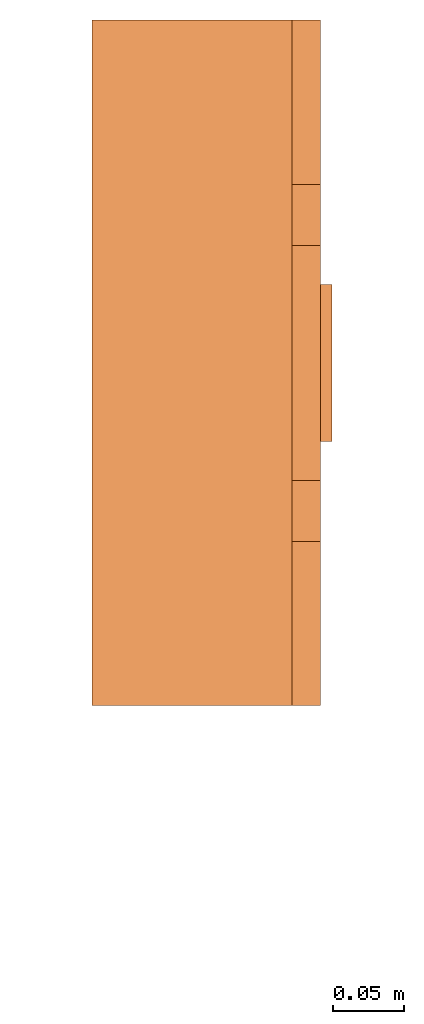
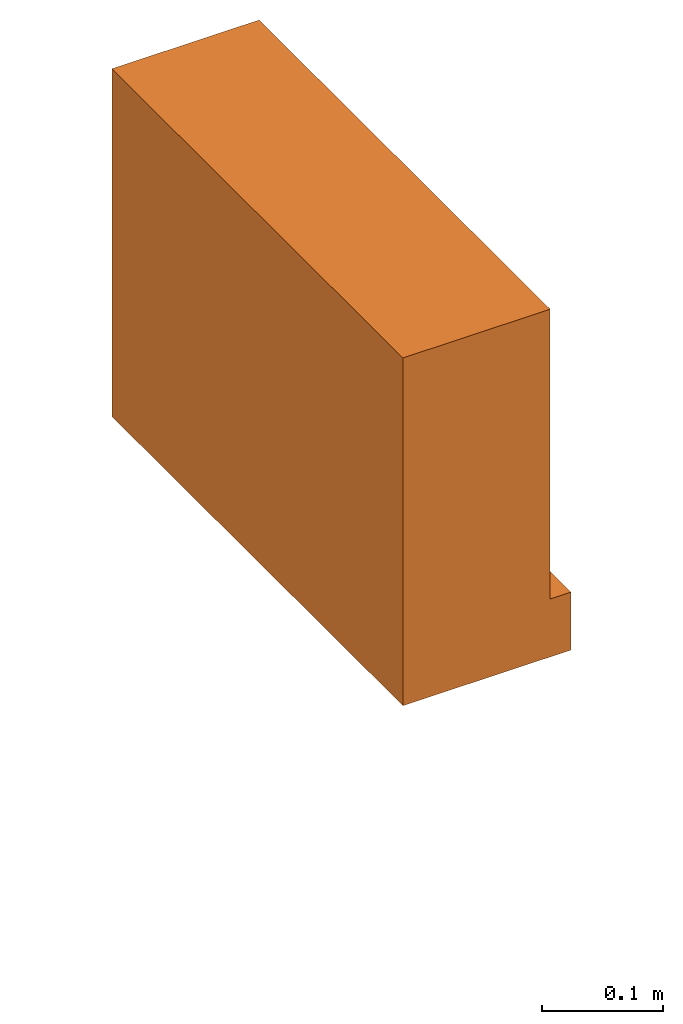
# One storey, part 3 of 3: 1 proxy.
"""IFC2X3 building model written with IfcOpenShell, lengths in millimetres."""

from ifc_helpers import new_model, entity, si_unit, converted_unit, derived_unit, direction, frame, origin, place, context, subcontext, project, spatial, faceted_brep, source, transform, mapped, material, material_list, type_object, type_shapes, element, save


model = new_model("IFC2X3")

# Units and contexts
model_context = context("Model", 3, precision=0.01, world=origin(), true_north=direction((6.12303176911189e-17, 1.0)))
body_context = subcontext(model_context, "Body", "Model", "MODEL_VIEW")
ifc_project = project(units=[si_unit("LENGTHUNIT", "METRE", prefix="MILLI"), si_unit("AREAUNIT", "SQUARE_METRE"), si_unit("VOLUMEUNIT", "CUBIC_METRE"), converted_unit("PLANEANGLEUNIT", "DEGREE", entity("IfcRatioMeasure", 0.0174532925199433), si_unit("PLANEANGLEUNIT", "RADIAN"), dimensions=[0, 0, 0, 0, 0, 0, 0]), si_unit("MASSUNIT", "GRAM", prefix="KILO"), derived_unit("MASSDENSITYUNIT", [(si_unit("MASSUNIT", "GRAM", prefix="KILO"), 1), (si_unit("LENGTHUNIT", "METRE"), -3)]), derived_unit("MOMENTOFINERTIAUNIT", [(si_unit("LENGTHUNIT", "METRE"), 4)]), si_unit("TIMEUNIT", "SECOND"), si_unit("FREQUENCYUNIT", "HERTZ"), si_unit("THERMODYNAMICTEMPERATUREUNIT", "DEGREE_CELSIUS"), derived_unit("THERMALTRANSMITTANCEUNIT", [(si_unit("MASSUNIT", "GRAM", prefix="KILO"), 1), (si_unit("THERMODYNAMICTEMPERATUREUNIT", "KELVIN"), -1), (si_unit("TIMEUNIT", "SECOND"), -3)]), derived_unit("VOLUMETRICFLOWRATEUNIT", [(si_unit("LENGTHUNIT", "METRE"), 3), (si_unit("TIMEUNIT", "SECOND"), -1)]), derived_unit("MASSFLOWRATEUNIT", [(si_unit("MASSUNIT", "GRAM", prefix="KILO"), 1), (si_unit("TIMEUNIT", "SECOND"), -1)]), derived_unit("ROTATIONALFREQUENCYUNIT", [(si_unit("TIMEUNIT", "SECOND"), -1)]), si_unit("ELECTRICCURRENTUNIT", "AMPERE"), si_unit("ELECTRICVOLTAGEUNIT", "VOLT"), si_unit("POWERUNIT", "WATT"), si_unit("FORCEUNIT", "NEWTON", prefix="KILO"), si_unit("ILLUMINANCEUNIT", "LUX"), si_unit("LUMINOUSFLUXUNIT", "LUMEN"), si_unit("LUMINOUSINTENSITYUNIT", "CANDELA"), derived_unit("USERDEFINED", [(si_unit("MASSUNIT", "GRAM", prefix="KILO"), -1), (si_unit("LENGTHUNIT", "METRE"), -2), (si_unit("TIMEUNIT", "SECOND"), 3), (si_unit("LUMINOUSFLUXUNIT", "LUMEN"), 1)]), derived_unit("LINEARVELOCITYUNIT", [(si_unit("LENGTHUNIT", "METRE"), 1), (si_unit("TIMEUNIT", "SECOND"), -1)]), si_unit("PRESSUREUNIT", "PASCAL"), derived_unit("USERDEFINED", [(si_unit("LENGTHUNIT", "METRE"), -2), (si_unit("MASSUNIT", "GRAM", prefix="KILO"), 1), (si_unit("TIMEUNIT", "SECOND"), -2)]), derived_unit("LINEARFORCEUNIT", [(si_unit("MASSUNIT", "GRAM", prefix="KILO"), 1), (si_unit("LENGTHUNIT", "METRE"), 1), (si_unit("TIMEUNIT", "SECOND"), -2), (si_unit("LENGTHUNIT", "METRE"), -1)]), derived_unit("PLANARFORCEUNIT", [(si_unit("MASSUNIT", "GRAM", prefix="KILO"), 1), (si_unit("LENGTHUNIT", "METRE"), 1), (si_unit("TIMEUNIT", "SECOND"), -2), (si_unit("LENGTHUNIT", "METRE"), -2)])], contexts=[model_context])

# Site, building, storey
site_placement = place(None, frame((0.0, 2493.83037508239, 0.0)))
site = spatial("IfcSite", under=ifc_project, at=site_placement, CompositionType="ELEMENT")
building_placement = place(site_placement, origin())
building = spatial("IfcBuilding", under=site, at=building_placement, CompositionType="ELEMENT")
storey_placement = place(building_placement, frame((0.0, 0.0, 12000.0)))
storey = spatial("IfcBuildingStorey", under=building, at=storey_placement, Name="04", CompositionType="ELEMENT", Elevation=12000.0)

# Proxy
ifc_material_1 = material()
ifc_material_2 = material()
ifc_material_list = material_list([ifc_material_1, ifc_material_2])
building_element_proxy_type = type_object("IfcBuildingElementProxyType", PredefinedType="NOTDEFINED", material=ifc_material_1)
shared_shape = source(origin(), body_context, "Body", "Brep", [
    faceted_brep([(168.201612490282, 212.500000000001, 135.54049916809), (168.201612490282, 201.109127034741, 126.799974925206), (168.201612490282, 192.368602791857, 115.409101959946), (168.201612490282, 186.874079554102, 102.144149440585), (168.201612490282, 185.0, 87.9091019599461), (168.201612490282, 186.874079554102, 73.6740544793074), (168.201612490282, 192.368602791856, 60.4091019599461), (168.201612490282, 201.10912703474, 49.0182289946861), (168.201612490282, 212.500000000001, 40.2777047518019), (168.201612490282, 225.764952519362, 34.7831815140474), (168.201612490282, 240.0, 32.9091019599461), (168.201612490282, 254.235047480639, 34.7831815140472), (168.201612490282, 267.5, 40.2777047518019), (168.201612490282, 278.890872965261, 49.0182289946858), (168.201612490282, 287.631397208145, 60.4091019599458), (168.201612490282, 293.125920445899, 73.6740544793071), (168.201612490282, 295.0, 87.9091019599458), (168.201612490282, 293.125920445899, 102.144149440584), (168.201612490282, 287.631397208145, 115.409101959946), (168.201612490282, 278.890872965261, 126.799974925206), (168.201612490282, 267.500000000001, 135.54049916809), (168.201612490282, 254.235047480639, 141.035022405845), (168.201612490282, 240.0, 142.909101959946), (168.201612490282, 225.764952519362, 141.035022405845), (160.0, 225.764952519362, 34.7831815140474), (160.0, 212.500000000001, 40.2777047518019), (160.0, 201.10912703474, 49.0182289946861), (160.0, 192.368602791856, 60.4091019599461), (160.0, 186.874079554102, 73.6740544793074), (160.0, 185.0, 87.9091019599463), (160.0, 186.874079554102, 102.144149440585), (160.0, 192.368602791857, 115.409101959946), (160.0, 201.109127034741, 126.799974925206), (160.0, 212.500000000001, 135.54049916809), (160.0, 225.764952519362, 141.035022405845), (160.0, 240.0, 142.909101959946), (160.0, 254.235047480639, 141.035022405845), (160.0, 267.500000000001, 135.54049916809), (160.0, 278.890872965261, 126.799974925206), (160.0, 287.631397208145, 115.409101959946), (160.0, 293.125920445899, 102.144149440584), (160.0, 295.0, 87.9091019599458), (160.0, 293.125920445899, 73.6740544793071), (160.0, 287.631397208145, 60.4091019599458), (160.0, 278.890872965261, 49.0182289946858), (160.0, 267.5, 40.2777047518019), (160.0, 254.235047480639, 34.7831815140472), (160.0, 240.0, 32.9091019599461)], [[[0, 1, 2, 3, 4, 5, 6, 7, 8, 9, 10, 11, 12, 13, 14, 15, 16, 17, 18, 19, 20, 21, 22, 23]], [[24, 25, 26, 27, 28, 29, 30, 31, 32, 33, 34, 35, 36, 37, 38, 39, 40, 41, 42, 43, 44, 45, 46, 47]], [[40, 17, 16, 41]], [[39, 18, 17, 40]], [[20, 19, 38, 37]], [[39, 38, 19, 18]], [[21, 20, 37, 36]], [[22, 21, 36, 35]], [[34, 23, 22, 35]], [[33, 0, 23, 34]], [[2, 1, 32, 31]], [[33, 32, 1, 0]], [[3, 2, 31, 30]], [[4, 3, 30, 29]], [[28, 5, 4, 29]], [[27, 6, 5, 28]], [[8, 7, 26, 25]], [[27, 26, 7, 6]], [[9, 8, 25, 24]], [[10, 9, 24, 47]], [[46, 11, 10, 47]], [[45, 12, 11, 46]], [[14, 13, 44, 43]], [[45, 44, 13, 12]], [[15, 14, 43, 42]], [[16, 15, 42, 41]]]),
    faceted_brep([(160.0, 0.0, 0.0), (160.0, 480.0, 0.0), (160.0, 480.0, 58.2870579365997), (160.0, 365.0, 58.2870579366005), (160.0, 322.247482084292, 175.748635534839), (160.0, 157.75251791571, 175.748635534839), (160.0, 115.0, 58.2870579366), (160.0, 0.0, 58.2870579365997), (0.0, 480.0, 0.0), (0.0, 0.0, 0.0), (0.0, 0.0, 350.0), (0.0, 480.0, 350.0), (140.211167148102, 480.0, 350.0), (140.211167148102, 480.0, 58.2870579365997), (140.211167148102, 0.0, 350.0), (140.211167148102, 0.0, 58.2870579365997), (140.211167148102, 365.0, 58.2870579366), (140.211167148102, 115.0, 58.2870579366), (140.211167148102, 157.75251791571, 175.748635534839), (140.211167148102, 322.247482084292, 175.748635534839)], [[[0, 1, 2, 3, 4, 5, 6, 7]], [[8, 9, 10, 11]], [[8, 11, 12, 13, 2, 1]], [[11, 10, 14, 12]], [[10, 9, 0, 7, 15, 14]], [[1, 0, 9, 8]], [[16, 13, 12, 14, 15, 17, 18, 19]], [[13, 16, 3, 2]], [[17, 15, 7, 6]], [[18, 17, 6, 5]], [[19, 18, 5, 4]], [[16, 19, 4, 3]]]),
])
type_shapes(building_element_proxy_type, [shared_shape])
proxy_placement = place(storey_placement, frame((55269.9984741216, 16784.3301703588, 1500.0)))
element("IfcBuildingElementProxy", 1, at=proxy_placement, inside=storey, type_object=building_element_proxy_type, material=ifc_material_list, context=body_context, shape_type="MappedRepresentation", body=[
    mapped(shared_shape, transform((0.0, 0.0, 0.0), scale=1.0)),
])

save(model, "model.ifc")
